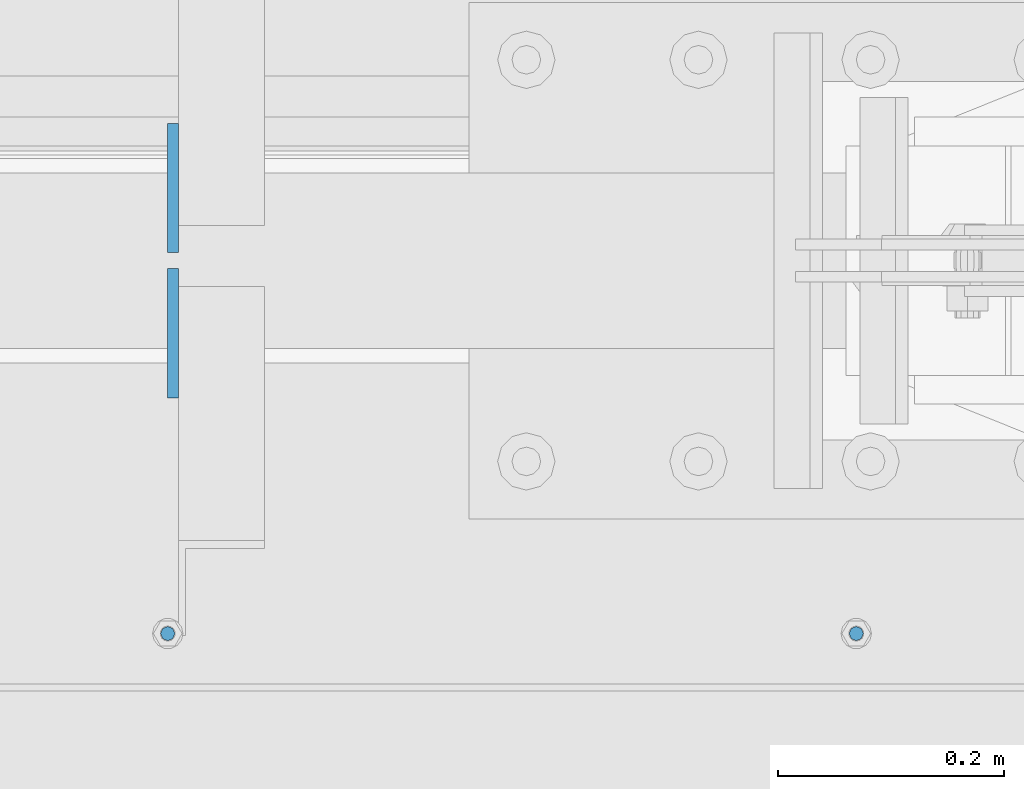
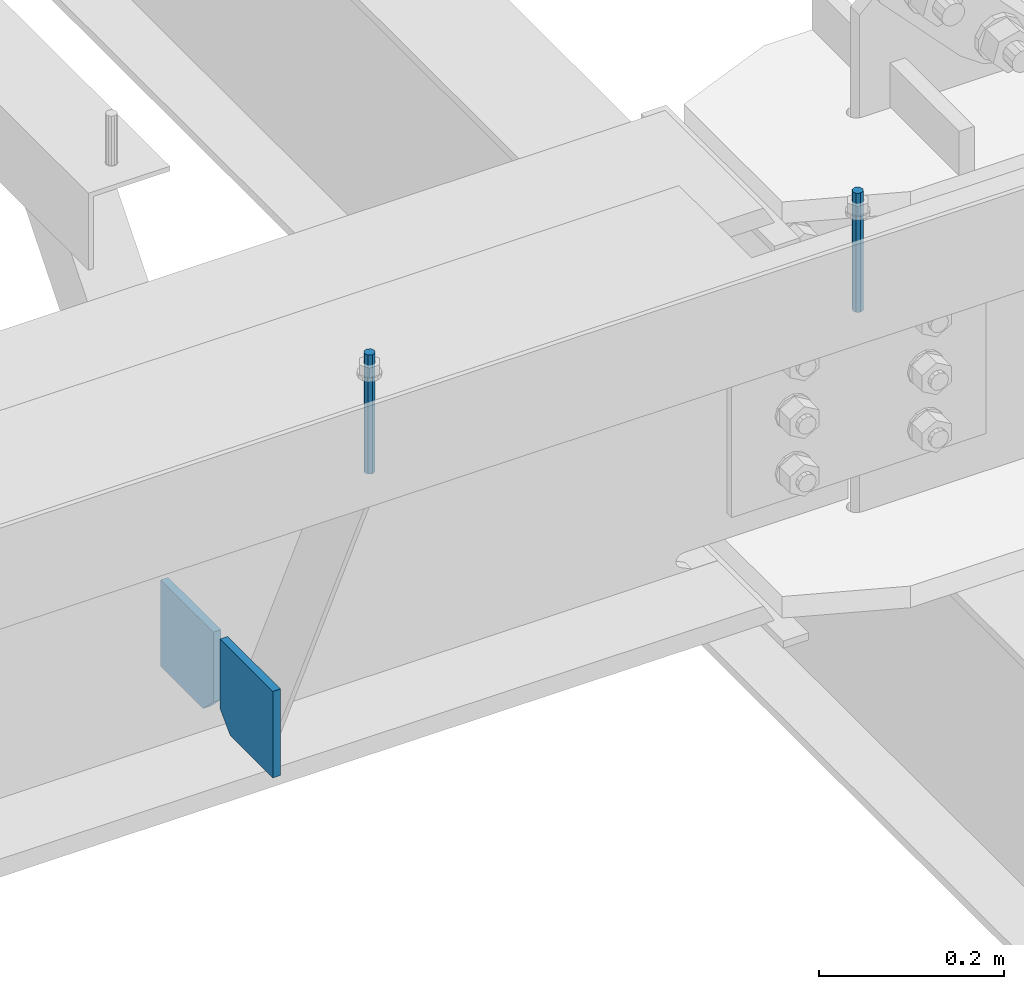
# One storey, part 453 of 1179: 4 columns, 1 element without a shape of its own.
"""IFC2X3 building model written with IfcOpenShell, lengths in millimetres."""

import ifcopenshell
import ifcopenshell.guid

model = None  # the IFC model being written
_history = None  # IfcOwnerHistory: only IFC2X3 demands one
_inside = {}  # id of a spatial element -> (the spatial element, [elements in it])
_under = {}  # id of a project, library or spatial element -> (it, [spatial elements below it])
_declared = {}  # id of a project -> (the project, [libraries it declares])
_typed = {}  # id of a type object -> (the type object, [elements of that type])
_made_of = {}  # id of a material, layer set ... -> (it, [elements and type objects made of it])


def new_model(schema):
    """Start an empty IFC model of exactly this schema.

    Asked for "IFC4X3", IfcOpenShell would pick the latest addendum, in which some entities
    have other attributes; the version numbers below select the first issue.
    IFC2X3 requires an IfcOwnerHistory on every rooted entity: one is made here for all.
    """
    global model, _history
    if schema == "IFC4X3":
        model = ifcopenshell.file(schema_version=(4, 3, 0, 0))
    else:
        model = ifcopenshell.file(schema=schema)
    _inside.clear()
    _under.clear()
    _declared.clear()
    _typed.clear()
    _made_of.clear()
    _history = None
    if model.schema == "IFC2X3":
        org = make("IfcOrganization", Name="unknown")
        user = make(
            "IfcPersonAndOrganization",
            ThePerson=make("IfcPerson", FamilyName="unknown"),
            TheOrganization=org,
        )
        app = make(
            "IfcApplication",
            ApplicationDeveloper=org,
            Version="unknown",
            ApplicationFullName="unknown",
            ApplicationIdentifier="unknown",
        )
        _history = make(
            "IfcOwnerHistory",
            OwningUser=user,
            OwningApplication=app,
            ChangeAction="ADDED",
            CreationDate=0,
        )
    return model


def make(cls, **values):
    """One entity of the class cls with the attributes given. An attribute that is None is left unset."""
    return model.create_entity(
        cls, **{name: value for name, value in values.items() if value is not None}
    )


def rooted(cls, **values):
    """An entity with a GlobalId (a new one), such as an element, a storey or a relation."""
    return make(cls, GlobalId=ifcopenshell.guid.new(), OwnerHistory=_history, **values)


def si_unit(unit_type, name, prefix=None):
    """IfcSIUnit, for example si_unit("LENGTHUNIT", "METRE", prefix="MILLI")."""
    return make("IfcSIUnit", UnitType=unit_type, Prefix=prefix, Name=name)


def assignment(units):
    """IfcUnitAssignment: the units of a project."""
    return None if units is None else make("IfcUnitAssignment", Units=units)


def point(xyz):
    """IfcCartesianPoint."""
    return None if xyz is None else make("IfcCartesianPoint", Coordinates=xyz)


def direction(xyz):
    """IfcDirection."""
    return None if xyz is None else make("IfcDirection", DirectionRatios=xyz)


def frame(location, z_axis=None, x_axis=None):
    """IfcAxis2Placement3D, a coordinate frame: its origin and axes. An axis left out is left unset."""
    return make(
        "IfcAxis2Placement3D",
        Location=point(location),
        Axis=direction(z_axis),
        RefDirection=direction(x_axis),
    )


def origin_with_axes():
    """The frame at (0, 0, 0) with the z axis (0, 0, 1) and the x axis (1, 0, 0) written out."""
    return frame((0.0, 0.0, 0.0), z_axis=(0.0, 0.0, 1.0), x_axis=(1.0, 0.0, 0.0))


def place(relative_to, where):
    """IfcLocalPlacement: puts the frame where relative to a parent placement (None: the world)."""
    return make(
        "IfcLocalPlacement", PlacementRelTo=relative_to, RelativePlacement=where
    )


def context(
    kind, dimensions, precision=None, world=None, true_north=None, identifier=None
):
    """IfcGeometricRepresentationContext, for example the 3D "Model" context."""
    return make(
        "IfcGeometricRepresentationContext",
        ContextIdentifier=identifier,
        ContextType=kind,
        CoordinateSpaceDimension=dimensions,
        Precision=precision,
        WorldCoordinateSystem=world,
        TrueNorth=true_north,
    )


def subcontext(parent, identifier, kind, view, scale=None):
    """IfcGeometricRepresentationSubContext, for example "Body" below "Model"."""
    return make(
        "IfcGeometricRepresentationSubContext",
        ContextIdentifier=identifier,
        ContextType=kind,
        ParentContext=parent,
        TargetScale=scale,
        TargetView=view,
    )


def project(units=None, contexts=None):
    """IfcProject with its units and contexts."""
    return rooted(
        "IfcProject",
        Name="project",
        RepresentationContexts=contexts,
        UnitsInContext=assignment(units),
    )


def spatial(cls, under=None, at=None, **own):
    """A site, building, storey or space (cls), placed at a placement, below another one or the project."""
    s = rooted(cls, ObjectPlacement=at, **own)
    if under is not None:
        _under.setdefault(under.id(), (under, []))[1].append(s)
    return s


def faces_of(points, faces, orient=None, outer=None):
    """IfcFace entities. A face is a list of loops; a loop is a list of indices into points, from 0.

    orient and outer hold one flag for each loop. By default every Orientation is true, the
    first loop of a face is its IfcFaceOuterBound and the others are IfcFaceBound.
    """
    made = []
    for i, loops in enumerate(faces):
        bounds = []
        for j, loop in enumerate(loops):
            is_outer = j == 0 if outer is None else outer[i][j]
            bounds.append(
                make(
                    "IfcFaceOuterBound" if is_outer else "IfcFaceBound",
                    Bound=make("IfcPolyLoop", Polygon=[points[k] for k in loop]),
                    Orientation=True if orient is None else orient[i][j],
                )
            )
        made.append(make("IfcFace", Bounds=bounds))
    return made


def faceted_brep(points, faces, orient=None, outer=None, voids=None):
    """IfcFacetedBrep: a solid bounded by flat faces; with voids (closed shells), ...WithVoids."""
    shared = [point(p) for p in points]
    hull = make("IfcClosedShell", CfsFaces=faces_of(shared, faces, orient, outer))
    if voids is None:
        return make("IfcFacetedBrep", Outer=hull)
    return make(
        "IfcFacetedBrepWithVoids",
        Outer=hull,
        Voids=[
            make(cls, CfsFaces=faces_of(shared, fs, o, b)) for cls, fs, o, b in voids
        ],
    )


def shape(context_of_items, identifier, shape_type, items):
    """IfcShapeRepresentation: the items that make up one representation, for example the "Body"."""
    return make(
        "IfcShapeRepresentation",
        ContextOfItems=context_of_items,
        RepresentationIdentifier=identifier,
        RepresentationType=shape_type,
        Items=items,
    )


def material(Name=None, Category=None):
    """IfcMaterial."""
    return make("IfcMaterial", Name=Name, Category=Category)


def made_of(thing, what):
    """Note that an element or type object is made of a material, layer set ...; save() writes the relation."""
    if what is not None:
        _made_of.setdefault(what.id(), (what, []))[1].append(thing)
    return thing


def type_object(cls, material=None, **own):
    """A type object (cls), such as IfcWallType, which elements share."""
    return made_of(rooted(cls, **own), material)


def element(
    cls,
    number,
    at=None,
    inside=None,
    cuts=None,
    type_object=None,
    material=None,
    context=None,
    identifier="Body",
    shape_type=None,
    held_by="IfcProductDefinitionShape",
    body=None,
    shapes=None,
    **own,
):
    """One element of the class cls, such as IfcWall. Its Tag is "e" and its number.

    at: its placement. inside: the storey or other place that contains it. cuts: it is an
    opening in that element (IfcRelVoidsElement). A single representation is given by context,
    identifier, shape_type and body (its items); several are given by shapes. held_by: the class
    of the entity that holds the representations. save() writes the other relations.
    """
    e = rooted(cls, Tag="e%d" % number, ObjectPlacement=at, **own)
    if body is not None:
        shapes = [shape(context, identifier, shape_type, body)]
    if shapes is not None:
        e.Representation = make(held_by, Representations=shapes)
    if inside is not None:
        _inside.setdefault(inside.id(), (inside, []))[1].append(e)
    if cuts is not None:
        rooted(
            "IfcRelVoidsElement", RelatingBuildingElement=cuts, RelatedOpeningElement=e
        )
    if type_object is not None:
        _typed.setdefault(type_object.id(), (type_object, []))[1].append(e)
    return made_of(e, material)


def aggregate(whole, parts):
    """IfcRelAggregates: a whole, such as a stair, and the parts it consists of."""
    return rooted("IfcRelAggregates", RelatingObject=whole, RelatedObjects=parts)


def save(model, path):
    """Write the relations noted so far, then the file.

    IfcRelAggregates (storeys below a building ...), IfcRelContainedInSpatialStructure (elements
    in a storey), IfcRelDefinesByType, IfcRelAssociatesMaterial and IfcRelDeclares: one each for
    every whole, place, type object, material and project.
    """
    for whole, parts in _under.values():
        aggregate(whole, parts)
    for where, things in _inside.values():
        rooted(
            "IfcRelContainedInSpatialStructure",
            RelatedElements=things,
            RelatingStructure=where,
        )
    for kind, things in _typed.values():
        rooted("IfcRelDefinesByType", RelatedObjects=things, RelatingType=kind)
    for what, things in _made_of.values():
        rooted("IfcRelAssociatesMaterial", RelatedObjects=things, RelatingMaterial=what)
    for by, libraries in _declared.values():
        rooted("IfcRelDeclares", RelatingContext=by, RelatedDefinitions=libraries)
    model.write(path)


model = new_model("IFC2X3")

# Units and contexts
model_context = context("Model", 3, precision=1e-05, world=origin_with_axes())
body_context = subcontext(model_context, "Body", "Model", "MODEL_VIEW")
ifc_project = project(units=[si_unit("LENGTHUNIT", "METRE", prefix="MILLI"), si_unit("AREAUNIT", "SQUARE_METRE"), si_unit("VOLUMEUNIT", "CUBIC_METRE"), si_unit("MASSUNIT", "GRAM", prefix="KILO"), si_unit("TIMEUNIT", "SECOND"), si_unit("PLANEANGLEUNIT", "RADIAN"), si_unit("SOLIDANGLEUNIT", "STERADIAN"), si_unit("THERMODYNAMICTEMPERATUREUNIT", "DEGREE_CELSIUS"), si_unit("LUMINOUSINTENSITYUNIT", "LUMEN")], contexts=[model_context])

# Site, building, storey
site_placement = place(None, origin_with_axes())
site = spatial("IfcSite", under=ifc_project, at=site_placement, CompositionType="ELEMENT")
building_placement = place(site_placement, origin_with_axes())
building = spatial("IfcBuilding", under=site, at=building_placement, Name="Undefined", CompositionType="ELEMENT")
storey_placement = place(building_placement, origin_with_axes())
storey = spatial("IfcBuildingStorey", under=building, at=storey_placement, Name="Undefined", CompositionType="ELEMENT", Elevation=0.0)

# Assembly, columns
assembly_placement = place(storey_placement, origin_with_axes())
assembly = element("IfcElementAssembly", 1, at=assembly_placement, inside=storey, Name="BEAM", AssemblyPlace="NOTDEFINED", PredefinedType="RIGID_FRAME")
ifc_material_1 = material(Name="STEEL/A36")
column_type_1 = type_object("IfcColumnType", PredefinedType="NOTDEFINED")
column_1_placement = place(assembly_placement, frame((15117.7625, 27115.29375, 7488.2375), z_axis=(0.0, -1.0, 0.0), x_axis=(0.0, 0.0, 1.0)))
column_1 = element("IfcColumn", 2, at=column_1_placement, type_object=column_type_1, material=ifc_material_1, Name="PLATE", context=body_context, shape_type="Brep", body=[
    faceted_brep([(22.2250000000004, 4.76250000000073, 57.1500000000015), (0.0, 4.76250000000073, 34.9249999999993), (0.0, -4.76250000000073, 34.9249999999993), (22.2250000000004, -4.76250000000073, 57.1500000000015), (114.300000000001, 4.76250000000073, 57.1500000000015), (114.300000000001, 4.76250000000073, -57.1500000000015), (0.0, 4.76250000000073, -57.1500000000015), (114.300000000001, -4.76250000000073, 57.1500000000015), (0.0, -4.76250000000073, -57.1500000000015), (114.300000000001, -4.76250000000073, -57.1500000000015)], [[[0, 1, 2, 3]], [[4, 5, 6, 1, 0]], [[7, 4, 0, 3]], [[8, 9, 7, 3, 2]], [[8, 6, 5, 9]], [[7, 9, 5, 4]], [[6, 8, 2, 1]]]),
])
column_2_placement = place(assembly_placement, frame((15117.7625, 26986.70625, 7488.2375), z_axis=(0.0, 1.0, 0.0), x_axis=(0.0, 0.0, 1.0)))
column_2 = element("IfcColumn", 3, at=column_2_placement, type_object=column_type_1, material=ifc_material_1, Name="PLATE", context=body_context, shape_type="Brep", body=[
    faceted_brep([(22.2250000000004, 4.76250000000073, 57.1500000000015), (0.0, 4.76250000000073, 34.9249999999993), (0.0, -4.76250000000073, 34.9249999999993), (22.2250000000004, -4.76250000000073, 57.1500000000015), (114.300000000001, 4.76250000000073, 57.1500000000015), (114.300000000001, 4.76250000000073, -57.1500000000015), (0.0, 4.76250000000073, -57.1500000000015), (114.300000000001, -4.76250000000073, 57.1500000000015), (0.0, -4.76250000000073, -57.1500000000015), (114.300000000001, -4.76250000000073, -57.1500000000015)], [[[0, 1, 2, 3]], [[4, 5, 6, 1, 0]], [[7, 4, 0, 3]], [[8, 9, 7, 3, 2]], [[8, 6, 5, 9]], [[7, 9, 5, 4]], [[6, 8, 2, 1]]]),
])
ifc_material_2 = material(Name="STEEL/A307")
column_type_2 = type_object("IfcColumnType", PredefinedType="NOTDEFINED")
column_3_placement = place(assembly_placement, frame((15722.6, 26720.8, 8020.05), z_axis=(0.0, 1.0, 0.0), x_axis=(0.0, 0.0, 1.0)))
column_3 = element("IfcColumn", 4, at=column_3_placement, type_object=column_type_2, material=ifc_material_2, Name="THREADED ROD", context=body_context, shape_type="Brep", body=[
    faceted_brep([(0.0, -6.34999999999854, 0.0), (0.0, -4.49012806053361, -4.49012806053452), (157.162499999999, -4.49012806053361, -4.49012806053361), (157.162499999999, -6.34999999999854, 0.0), (0.0, 0.0, -6.34999999999991), (157.162499999999, 0.0, -6.34999999999854), (0.0, 4.49012806053361, -4.49012806053452), (157.162499999999, 4.49012806053361, -4.49012806053361), (0.0, 6.34999999999854, 0.0), (157.162499999999, 6.34999999999854, 0.0), (0.0, 4.49012806053361, 4.49012806053452), (157.162499999999, 4.49012806053361, 4.49012806053361), (0.0, 0.0, 6.34999999999991), (157.162499999999, 0.0, 6.34999999999854), (0.0, -4.49012806053361, 4.49012806053452), (157.162499999999, -4.49012806053361, 4.49012806053361)], [[[0, 1, 2, 3]], [[1, 4, 5, 2]], [[4, 6, 7, 5]], [[6, 8, 9, 7]], [[8, 10, 11, 9]], [[10, 12, 13, 11]], [[12, 14, 15, 13]], [[14, 0, 3, 15]], [[5, 7, 9, 11, 13, 15, 3, 2]], [[14, 12, 10, 8, 6, 4, 1, 0]]]),
])
column_4_placement = place(assembly_placement, frame((15113.0, 26720.8, 8020.05), z_axis=(0.0, 1.0, 0.0), x_axis=(0.0, 0.0, 1.0)))
column_4 = element("IfcColumn", 5, at=column_4_placement, type_object=column_type_2, material=ifc_material_2, Name="THREADED ROD", context=body_context, shape_type="Brep", body=[
    faceted_brep([(0.0, -6.34999999999854, 0.0), (0.0, -4.49012806053361, -4.49012806053452), (157.162499999999, -4.49012806053361, -4.49012806053361), (157.162499999999, -6.34999999999854, 0.0), (0.0, 0.0, -6.34999999999991), (157.162499999999, 0.0, -6.34999999999854), (0.0, 4.49012806053361, -4.49012806053452), (157.162499999999, 4.49012806053361, -4.49012806053361), (0.0, 6.34999999999854, 0.0), (157.162499999999, 6.34999999999854, 0.0), (0.0, 4.49012806053361, 4.49012806053452), (157.162499999999, 4.49012806053361, 4.49012806053361), (0.0, 0.0, 6.34999999999991), (157.162499999999, 0.0, 6.34999999999854), (0.0, -4.49012806053361, 4.49012806053452), (157.162499999999, -4.49012806053361, 4.49012806053361)], [[[0, 1, 2, 3]], [[1, 4, 5, 2]], [[4, 6, 7, 5]], [[6, 8, 9, 7]], [[8, 10, 11, 9]], [[10, 12, 13, 11]], [[12, 14, 15, 13]], [[14, 0, 3, 15]], [[5, 7, 9, 11, 13, 15, 3, 2]], [[14, 12, 10, 8, 6, 4, 1, 0]]]),
])
aggregate(assembly, [column_3, column_4, column_1, column_2])

save(model, "model.ifc")
